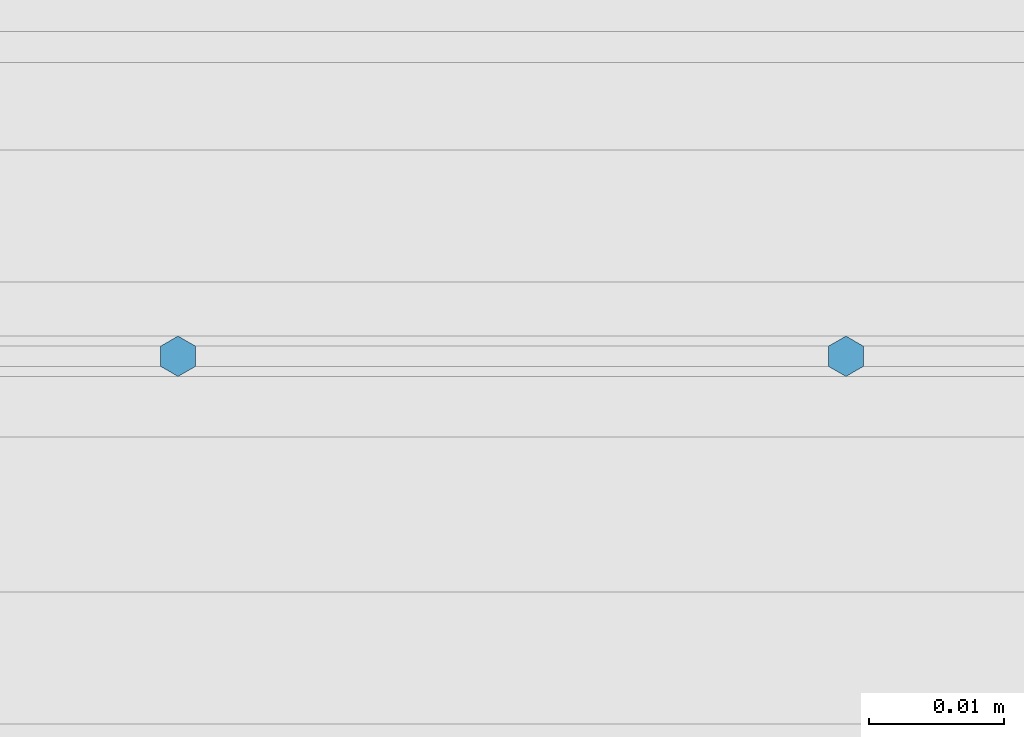
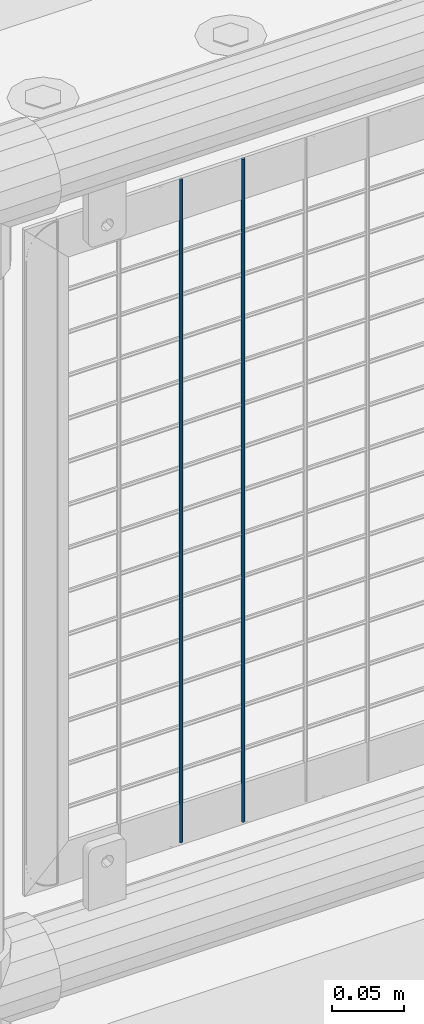
# One storey, part 62 of 208: 2 columns.
"""IFC2X3 building model written with IfcOpenShell, lengths in millimetres."""

from ifc_helpers import new_model, si_unit, frame, origin_with_axes, place, context, subcontext, project, spatial, faceted_brep, material, type_object, element, save


model = new_model("IFC2X3")

# Units and contexts
model_context = context("Model", 3, precision=1e-05, world=origin_with_axes())
body_context = subcontext(model_context, "Body", "Model", "MODEL_VIEW")
ifc_project = project(units=[si_unit("LENGTHUNIT", "METRE", prefix="MILLI"), si_unit("AREAUNIT", "SQUARE_METRE"), si_unit("VOLUMEUNIT", "CUBIC_METRE"), si_unit("MASSUNIT", "GRAM", prefix="KILO"), si_unit("TIMEUNIT", "SECOND"), si_unit("PLANEANGLEUNIT", "RADIAN"), si_unit("SOLIDANGLEUNIT", "STERADIAN"), si_unit("THERMODYNAMICTEMPERATUREUNIT", "DEGREE_CELSIUS"), si_unit("LUMINOUSINTENSITYUNIT", "LUMEN")], contexts=[model_context])

# Site, building, storey
site_placement = place(None, origin_with_axes())
site = spatial("IfcSite", under=ifc_project, at=site_placement, CompositionType="ELEMENT")
building_placement = place(site_placement, origin_with_axes())
building = spatial("IfcBuilding", under=site, at=building_placement, Name="Standard", CompositionType="ELEMENT")
storey_placement = place(building_placement, origin_with_axes())
storey = spatial("IfcBuildingStorey", under=building, at=storey_placement, Name="Undefined", CompositionType="ELEMENT", Elevation=0.0)

# Columns
ifc_material = material(Name="Misc_Undefined")
column_type = type_object("IfcColumnType", Name="D3", PredefinedType="NOTDEFINED")
for number, where, z_axis, x_axis in (
    (1, (-38400.035, 4670.5, 353.02), (-1.0, 0.0, 0.0), (0.0, 0.0, 1.0)),
    (2, (-38449.6896551724, 4670.5, 353.02), (-1.0, 0.0, 0.0), (0.0, 0.0, 1.0)),
):
    element("IfcColumn", number, at=place(storey_placement, frame(where, z_axis=z_axis, x_axis=x_axis)), inside=storey, type_object=column_type, material=ifc_material, ObjectType="D3", context=body_context, shape_type="Brep", body=[
        faceted_brep([(0.0, -1.49999999999909, 3.63797880709171e-12), (-7.27595761418343e-12, -0.749999999999091, -1.29903810567669), (560.0, -0.75, -1.29903810567703), (560.0, -1.5, 0.0), (-3.63797880709171e-12, 0.750000000000909, -1.29903810567669), (560.0, 0.75, -1.29903810567703), (0.0, 1.50000000000182, 3.63797880709171e-12), (560.0, 1.5, 0.0), (-3.63797880709171e-12, 0.750000000000909, 1.29903810567669), (560.0, 0.75, 1.29903810567703), (-7.27595761418343e-12, -0.749999999999091, 1.29903810567669), (560.0, -0.75, 1.29903810567703)], [[[0, 1, 2, 3]], [[1, 4, 5, 2]], [[4, 6, 7, 5]], [[6, 8, 9, 7]], [[8, 10, 11, 9]], [[10, 0, 3, 11]], [[5, 7, 9, 11, 3, 2]], [[10, 8, 6, 4, 1, 0]]]),
    ])

save(model, "model.ifc")
